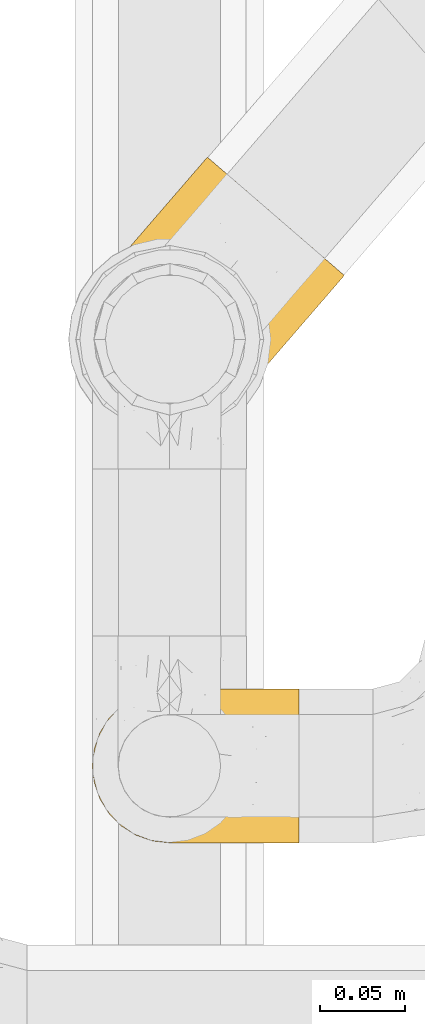
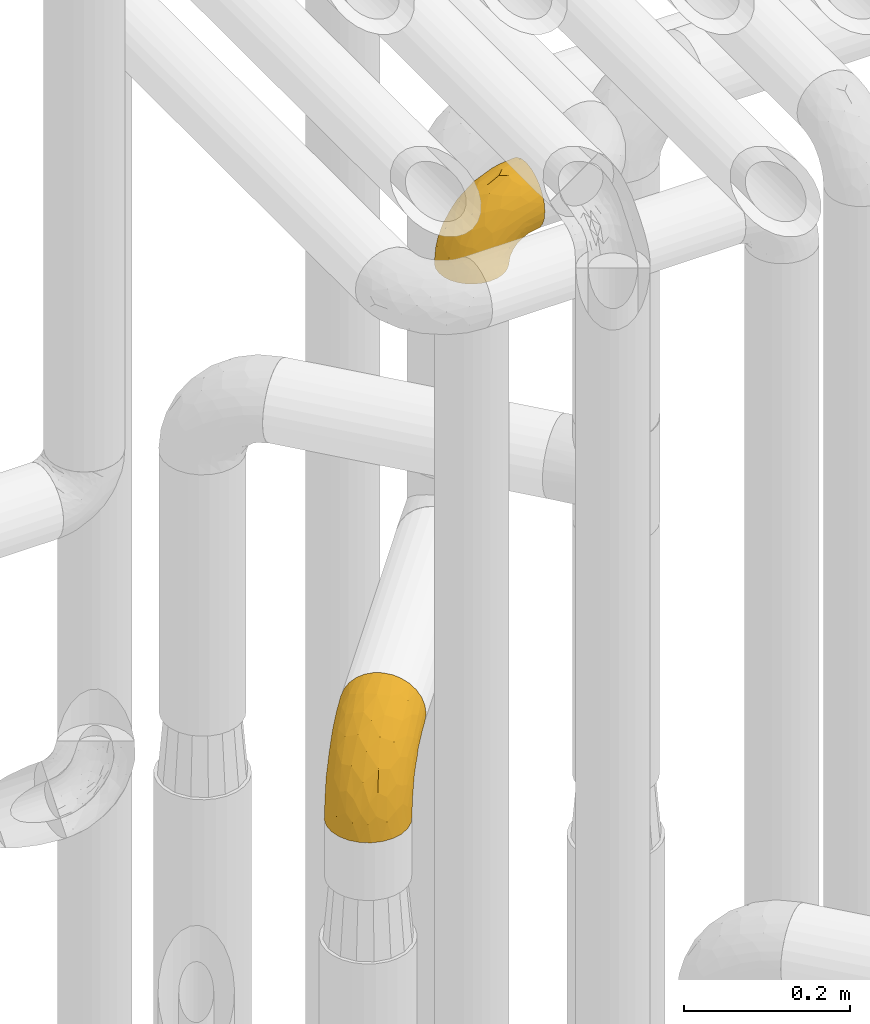
# One storey, part 228 of 827: 2 coverings.
"""IFC2X3 building model written with IfcOpenShell, lengths in millimetres."""

import ifcopenshell
import ifcopenshell.guid

model = None  # the IFC model being written
_history = None  # IfcOwnerHistory: only IFC2X3 demands one
_inside = {}  # id of a spatial element -> (the spatial element, [elements in it])
_under = {}  # id of a project, library or spatial element -> (it, [spatial elements below it])
_declared = {}  # id of a project -> (the project, [libraries it declares])
_typed = {}  # id of a type object -> (the type object, [elements of that type])
_made_of = {}  # id of a material, layer set ... -> (it, [elements and type objects made of it])


def new_model(schema):
    """Start an empty IFC model of exactly this schema.

    Asked for "IFC4X3", IfcOpenShell would pick the latest addendum, in which some entities
    have other attributes; the version numbers below select the first issue.
    IFC2X3 requires an IfcOwnerHistory on every rooted entity: one is made here for all.
    """
    global model, _history
    if schema == "IFC4X3":
        model = ifcopenshell.file(schema_version=(4, 3, 0, 0))
    else:
        model = ifcopenshell.file(schema=schema)
    _inside.clear()
    _under.clear()
    _declared.clear()
    _typed.clear()
    _made_of.clear()
    _history = None
    if model.schema == "IFC2X3":
        org = make("IfcOrganization", Name="unknown")
        user = make(
            "IfcPersonAndOrganization",
            ThePerson=make("IfcPerson", FamilyName="unknown"),
            TheOrganization=org,
        )
        app = make(
            "IfcApplication",
            ApplicationDeveloper=org,
            Version="unknown",
            ApplicationFullName="unknown",
            ApplicationIdentifier="unknown",
        )
        _history = make(
            "IfcOwnerHistory",
            OwningUser=user,
            OwningApplication=app,
            ChangeAction="ADDED",
            CreationDate=0,
        )
    return model


def make(cls, **values):
    """One entity of the class cls with the attributes given. An attribute that is None is left unset."""
    return model.create_entity(
        cls, **{name: value for name, value in values.items() if value is not None}
    )


def entity(cls, *values):
    """Any entity or typed value of the class cls, its attributes in the order of the schema. None: left unset."""
    e = model.create_entity(cls)
    for i, value in enumerate(values):
        if value is not None:
            e[i] = value
    return e


def rooted(cls, **values):
    """An entity with a GlobalId (a new one), such as an element, a storey or a relation."""
    return make(cls, GlobalId=ifcopenshell.guid.new(), OwnerHistory=_history, **values)


def si_unit(unit_type, name, prefix=None):
    """IfcSIUnit, for example si_unit("LENGTHUNIT", "METRE", prefix="MILLI")."""
    return make("IfcSIUnit", UnitType=unit_type, Prefix=prefix, Name=name)


def converted_unit(unit_type, name, factor, base, dimensions=None, offset=None):
    """IfcConversionBasedUnit, such as the inch: factor (a typed value) times the base unit."""
    return make(
        "IfcConversionBasedUnit"
        if offset is None
        else "IfcConversionBasedUnitWithOffset",
        ConversionOffset=offset,
        Dimensions=None
        if dimensions is None
        else entity("IfcDimensionalExponents", *dimensions),
        UnitType=unit_type,
        Name=name,
        ConversionFactor=make(
            "IfcMeasureWithUnit", ValueComponent=factor, UnitComponent=base
        ),
    )


def derived_unit(unit_type, elements):
    """IfcDerivedUnit: a product of units, each with its exponent."""
    return make(
        "IfcDerivedUnit",
        Elements=[
            make("IfcDerivedUnitElement", Unit=unit, Exponent=power)
            for unit, power in elements
        ],
        UnitType=unit_type,
    )


def assignment(units):
    """IfcUnitAssignment: the units of a project."""
    return None if units is None else make("IfcUnitAssignment", Units=units)


def point(xyz):
    """IfcCartesianPoint."""
    return None if xyz is None else make("IfcCartesianPoint", Coordinates=xyz)


def direction(xyz):
    """IfcDirection."""
    return None if xyz is None else make("IfcDirection", DirectionRatios=xyz)


def frame(location, z_axis=None, x_axis=None):
    """IfcAxis2Placement3D, a coordinate frame: its origin and axes. An axis left out is left unset."""
    return make(
        "IfcAxis2Placement3D",
        Location=point(location),
        Axis=direction(z_axis),
        RefDirection=direction(x_axis),
    )


def origin():
    """The frame at (0, 0, 0) with its axes left unset."""
    return frame((0.0, 0.0, 0.0))


def place(relative_to, where):
    """IfcLocalPlacement: puts the frame where relative to a parent placement (None: the world)."""
    return make(
        "IfcLocalPlacement", PlacementRelTo=relative_to, RelativePlacement=where
    )


def context(
    kind, dimensions, precision=None, world=None, true_north=None, identifier=None
):
    """IfcGeometricRepresentationContext, for example the 3D "Model" context."""
    return make(
        "IfcGeometricRepresentationContext",
        ContextIdentifier=identifier,
        ContextType=kind,
        CoordinateSpaceDimension=dimensions,
        Precision=precision,
        WorldCoordinateSystem=world,
        TrueNorth=true_north,
    )


def subcontext(parent, identifier, kind, view, scale=None):
    """IfcGeometricRepresentationSubContext, for example "Body" below "Model"."""
    return make(
        "IfcGeometricRepresentationSubContext",
        ContextIdentifier=identifier,
        ContextType=kind,
        ParentContext=parent,
        TargetScale=scale,
        TargetView=view,
    )


def project(units=None, contexts=None):
    """IfcProject with its units and contexts."""
    return rooted(
        "IfcProject",
        Name="project",
        RepresentationContexts=contexts,
        UnitsInContext=assignment(units),
    )


def spatial(cls, under=None, at=None, **own):
    """A site, building, storey or space (cls), placed at a placement, below another one or the project."""
    s = rooted(cls, ObjectPlacement=at, **own)
    if under is not None:
        _under.setdefault(under.id(), (under, []))[1].append(s)
    return s


def faces_of(points, faces, orient=None, outer=None):
    """IfcFace entities. A face is a list of loops; a loop is a list of indices into points, from 0.

    orient and outer hold one flag for each loop. By default every Orientation is true, the
    first loop of a face is its IfcFaceOuterBound and the others are IfcFaceBound.
    """
    made = []
    for i, loops in enumerate(faces):
        bounds = []
        for j, loop in enumerate(loops):
            is_outer = j == 0 if outer is None else outer[i][j]
            bounds.append(
                make(
                    "IfcFaceOuterBound" if is_outer else "IfcFaceBound",
                    Bound=make("IfcPolyLoop", Polygon=[points[k] for k in loop]),
                    Orientation=True if orient is None else orient[i][j],
                )
            )
        made.append(make("IfcFace", Bounds=bounds))
    return made


def faceted_brep(points, faces, orient=None, outer=None, voids=None):
    """IfcFacetedBrep: a solid bounded by flat faces; with voids (closed shells), ...WithVoids."""
    shared = [point(p) for p in points]
    hull = make("IfcClosedShell", CfsFaces=faces_of(shared, faces, orient, outer))
    if voids is None:
        return make("IfcFacetedBrep", Outer=hull)
    return make(
        "IfcFacetedBrepWithVoids",
        Outer=hull,
        Voids=[
            make(cls, CfsFaces=faces_of(shared, fs, o, b)) for cls, fs, o, b in voids
        ],
    )


def shape(context_of_items, identifier, shape_type, items):
    """IfcShapeRepresentation: the items that make up one representation, for example the "Body"."""
    return make(
        "IfcShapeRepresentation",
        ContextOfItems=context_of_items,
        RepresentationIdentifier=identifier,
        RepresentationType=shape_type,
        Items=items,
    )


def made_of(thing, what):
    """Note that an element or type object is made of a material, layer set ...; save() writes the relation."""
    if what is not None:
        _made_of.setdefault(what.id(), (what, []))[1].append(thing)
    return thing


def element(
    cls,
    number,
    at=None,
    inside=None,
    cuts=None,
    type_object=None,
    material=None,
    context=None,
    identifier="Body",
    shape_type=None,
    held_by="IfcProductDefinitionShape",
    body=None,
    shapes=None,
    **own,
):
    """One element of the class cls, such as IfcWall. Its Tag is "e" and its number.

    at: its placement. inside: the storey or other place that contains it. cuts: it is an
    opening in that element (IfcRelVoidsElement). A single representation is given by context,
    identifier, shape_type and body (its items); several are given by shapes. held_by: the class
    of the entity that holds the representations. save() writes the other relations.
    """
    e = rooted(cls, Tag="e%d" % number, ObjectPlacement=at, **own)
    if body is not None:
        shapes = [shape(context, identifier, shape_type, body)]
    if shapes is not None:
        e.Representation = make(held_by, Representations=shapes)
    if inside is not None:
        _inside.setdefault(inside.id(), (inside, []))[1].append(e)
    if cuts is not None:
        rooted(
            "IfcRelVoidsElement", RelatingBuildingElement=cuts, RelatedOpeningElement=e
        )
    if type_object is not None:
        _typed.setdefault(type_object.id(), (type_object, []))[1].append(e)
    return made_of(e, material)


def aggregate(whole, parts):
    """IfcRelAggregates: a whole, such as a stair, and the parts it consists of."""
    return rooted("IfcRelAggregates", RelatingObject=whole, RelatedObjects=parts)


def save(model, path):
    """Write the relations noted so far, then the file.

    IfcRelAggregates (storeys below a building ...), IfcRelContainedInSpatialStructure (elements
    in a storey), IfcRelDefinesByType, IfcRelAssociatesMaterial and IfcRelDeclares: one each for
    every whole, place, type object, material and project.
    """
    for whole, parts in _under.values():
        aggregate(whole, parts)
    for where, things in _inside.values():
        rooted(
            "IfcRelContainedInSpatialStructure",
            RelatedElements=things,
            RelatingStructure=where,
        )
    for kind, things in _typed.values():
        rooted("IfcRelDefinesByType", RelatedObjects=things, RelatingType=kind)
    for what, things in _made_of.values():
        rooted("IfcRelAssociatesMaterial", RelatedObjects=things, RelatingMaterial=what)
    for by, libraries in _declared.values():
        rooted("IfcRelDeclares", RelatingContext=by, RelatedDefinitions=libraries)
    model.write(path)


model = new_model("IFC2X3")

# Units and contexts
model_context = context("Model", 3, precision=0.01, world=origin(), true_north=direction((6.12303176911189e-17, 1.0)))
body_context = subcontext(model_context, "Body", "Model", "MODEL_VIEW")
ifc_project = project(units=[si_unit("LENGTHUNIT", "METRE", prefix="MILLI"), si_unit("AREAUNIT", "SQUARE_METRE"), si_unit("VOLUMEUNIT", "CUBIC_METRE"), converted_unit("PLANEANGLEUNIT", "DEGREE", entity("IfcRatioMeasure", 0.0174532925199433), si_unit("PLANEANGLEUNIT", "RADIAN"), dimensions=[0, 0, 0, 0, 0, 0, 0]), si_unit("MASSUNIT", "GRAM", prefix="KILO"), derived_unit("MASSDENSITYUNIT", [(si_unit("MASSUNIT", "GRAM", prefix="KILO"), 1), (si_unit("LENGTHUNIT", "METRE"), -3)]), derived_unit("MOMENTOFINERTIAUNIT", [(si_unit("LENGTHUNIT", "METRE"), 4)]), si_unit("TIMEUNIT", "SECOND"), si_unit("FREQUENCYUNIT", "HERTZ"), si_unit("THERMODYNAMICTEMPERATUREUNIT", "DEGREE_CELSIUS"), derived_unit("THERMALTRANSMITTANCEUNIT", [(si_unit("MASSUNIT", "GRAM", prefix="KILO"), 1), (si_unit("THERMODYNAMICTEMPERATUREUNIT", "KELVIN"), -1), (si_unit("TIMEUNIT", "SECOND"), -3)]), derived_unit("VOLUMETRICFLOWRATEUNIT", [(si_unit("LENGTHUNIT", "METRE"), 3), (si_unit("TIMEUNIT", "SECOND"), -1)]), derived_unit("MASSFLOWRATEUNIT", [(si_unit("MASSUNIT", "GRAM", prefix="KILO"), 1), (si_unit("TIMEUNIT", "SECOND"), -1)]), derived_unit("ROTATIONALFREQUENCYUNIT", [(si_unit("TIMEUNIT", "SECOND"), -1)]), si_unit("ELECTRICCURRENTUNIT", "AMPERE"), si_unit("ELECTRICVOLTAGEUNIT", "VOLT"), si_unit("POWERUNIT", "WATT"), si_unit("FORCEUNIT", "NEWTON", prefix="KILO"), si_unit("ILLUMINANCEUNIT", "LUX"), si_unit("LUMINOUSFLUXUNIT", "LUMEN"), si_unit("LUMINOUSINTENSITYUNIT", "CANDELA"), derived_unit("USERDEFINED", [(si_unit("MASSUNIT", "GRAM", prefix="KILO"), -1), (si_unit("LENGTHUNIT", "METRE"), -2), (si_unit("TIMEUNIT", "SECOND"), 3), (si_unit("LUMINOUSFLUXUNIT", "LUMEN"), 1)]), derived_unit("LINEARVELOCITYUNIT", [(si_unit("LENGTHUNIT", "METRE"), 1), (si_unit("TIMEUNIT", "SECOND"), -1)]), si_unit("PRESSUREUNIT", "PASCAL"), derived_unit("USERDEFINED", [(si_unit("LENGTHUNIT", "METRE"), -2), (si_unit("MASSUNIT", "GRAM", prefix="KILO"), 1), (si_unit("TIMEUNIT", "SECOND"), -2)]), derived_unit("LINEARFORCEUNIT", [(si_unit("MASSUNIT", "GRAM", prefix="KILO"), 1), (si_unit("LENGTHUNIT", "METRE"), 1), (si_unit("TIMEUNIT", "SECOND"), -2), (si_unit("LENGTHUNIT", "METRE"), -1)]), derived_unit("PLANARFORCEUNIT", [(si_unit("MASSUNIT", "GRAM", prefix="KILO"), 1), (si_unit("LENGTHUNIT", "METRE"), 1), (si_unit("TIMEUNIT", "SECOND"), -2), (si_unit("LENGTHUNIT", "METRE"), -2)])], contexts=[model_context])

# Site, building, storey
site_placement = place(None, origin())
site = spatial("IfcSite", under=ifc_project, at=site_placement, CompositionType="ELEMENT")
building_placement = place(site_placement, origin())
building = spatial("IfcBuilding", under=site, at=building_placement, CompositionType="ELEMENT")
storey_placement = place(building_placement, frame((0.0, 0.0, 28200.0)))
storey = spatial("IfcBuildingStorey", under=building, at=storey_placement, Name="08", CompositionType="ELEMENT", Elevation=28200.0)

# Coverings
covering_1_placement = place(storey_placement, frame((36582.9, 12284.43, 2922.4)))
element("IfcCovering", 1, at=covering_1_placement, inside=storey, Name=":ADSK_", ObjectType=":ADSK_", PredefinedType="INSULATION", context=body_context, shape_type="Brep", body=[
    faceted_brep([(36.69, 2.73, 1.6), (27.15, 6.07, 1.6), (18.59, 11.45, 1.6), (11.44, 18.6, 1.6), (6.06, 27.16, 1.6), (2.73, 36.7, 1.6), (1.6, 46.75, 1.6), (2.73, 56.8, 1.6), (6.07, 66.34, 1.6), (11.45, 74.9, 1.6), (18.6, 82.05, 1.6), (27.16, 87.43, 1.6), (36.7, 90.76, 1.6), (46.75, 91.9, 1.6), (56.8, 90.76, 1.6), (66.34, 87.42, 1.6), (74.9, 82.04, 1.6), (82.05, 74.89, 1.6), (87.43, 66.33, 1.6), (90.76, 56.79, 1.6), (91.9, 46.75, 1.6), (90.76, 36.69, 1.6), (87.42, 27.15, 1.6), (82.04, 18.59, 1.6), (74.89, 11.44, 1.6), (66.33, 6.06, 1.6), (56.79, 2.73, 1.6), (46.75, 1.6, 1.6), (122.75, 58.43, 33.98), (122.75, 69.32, 38.49), (122.75, 78.67, 45.67), (122.75, 85.85, 55.02), (122.75, 90.36, 65.91), (122.75, 91.9, 77.6), (122.75, 90.36, 89.28), (122.75, 85.85, 100.17), (122.75, 78.67, 109.52), (122.75, 69.32, 116.7), (122.75, 58.43, 121.21), (122.75, 46.75, 122.75), (122.75, 35.06, 121.21), (122.75, 24.17, 116.7), (122.75, 14.82, 109.52), (122.75, 7.64, 100.17), (122.75, 3.13, 89.28), (122.75, 1.6, 77.6), (122.75, 3.13, 65.91), (122.75, 7.64, 55.02), (122.75, 14.82, 45.67), (122.75, 24.17, 38.49), (122.75, 35.06, 33.98), (122.75, 46.75, 32.45), (24.73, 46.75, 72.81), (29.08, 38.29, 77.17), (38.13, 46.75, 86.21), (85.31, 46.75, 116.82), (93.59, 38.96, 118.49), (100.54, 46.75, 119.23), (63.54, 33.86, 105.14), (38.98, 31.42, 85.37), (50.71, 21.63, 89.33), (93.33, 30.84, 116.14), (75.2, 22.16, 105.06), (100.46, 20.56, 112.15), (41.6, 2.29, 22.95), (80.86, 7.18, 89.91), (94.87, 12.6, 103.39), (67.96, 14.0, 93.6), (52.16, 2.81, 51.41), (52.1, 6.65, 67.71), (36.74, 6.11, 43.53), (17.11, 16.62, 30.91), (23.24, 9.76, 23.58), (29.18, 12.46, 50.07), (52.53, 1.6, 30.68), (60.77, 1.6, 43.01), (69.01, 1.6, 55.34), (100.68, 2.46, 83.48), (103.79, 5.91, 94.96), (16.37, 36.97, 57.29), (7.52, 46.75, 39.03), (7.31, 33.09, 30.66), (93.66, 1.6, 71.81), (102.83, 1.6, 73.63), (112.01, 1.6, 75.46), (18.17, 25.62, 51.57), (71.97, 3.14, 73.13), (9.83, 23.92, 23.16), (5.11, 46.75, 23.8), (45.97, 13.58, 75.6), (48.88, 1.6, 12.33), (50.71, 1.6, 21.51), (22.83, 18.5, 50.46), (51.54, 46.75, 99.61), (81.33, 1.6, 63.57), (31.74, 4.96, 21.26), (32.48, 20.84, 69.54), (68.42, 46.75, 108.21), (25.33, 30.52, 68.42), (16.13, 46.75, 55.92), (92.29, 27.29, 19.36), (94.12, 36.89, 15.76), (100.97, 33.6, 26.13), (95.91, 2.54, 62.78), (107.9, 3.27, 63.65), (87.24, 16.85, 24.34), (95.46, 21.91, 28.46), (90.41, 13.5, 33.53), (74.17, 3.96, 39.46), (83.77, 3.52, 51.05), (76.72, 12.17, 10.94), (84.44, 18.93, 14.55), (76.42, 9.34, 22.21), (90.07, 3.12, 57.05), (99.69, 5.67, 54.0), (61.74, 2.51, 29.19), (58.16, 2.53, 18.85), (112.6, 8.35, 52.84), (110.45, 35.39, 31.47), (107.32, 46.75, 28.31), (108.48, 15.1, 43.0), (66.63, 5.27, 16.9), (115.23, 27.43, 35.98), (105.79, 24.89, 33.91), (89.6, 29.71, 9.97), (69.39, 5.07, 25.93), (66.99, 2.88, 35.61), (102.31, 9.69, 47.45), (99.54, 15.51, 38.26), (55.27, 2.27, 11.7), (82.03, 10.03, 30.13), (94.71, 46.75, 12.12), (96.03, 46.75, 17.02), (94.11, 8.83, 44.39), (84.21, 7.16, 39.83), (101.67, 46.75, 22.67), (112.22, 46.75, 29.63), (108.48, 78.39, 43.0), (102.31, 83.8, 47.45), (99.54, 77.97, 38.26), (94.11, 84.66, 44.38), (110.46, 58.1, 31.47), (76.74, 81.31, 10.93), (50.71, 91.9, 21.51), (58.17, 90.96, 18.84), (55.27, 91.22, 11.7), (94.12, 56.59, 15.76), (92.3, 66.18, 19.36), (100.98, 59.87, 26.14), (69.41, 88.42, 25.94), (76.44, 84.13, 22.21), (66.65, 88.22, 16.9), (115.24, 66.06, 35.98), (102.83, 91.9, 73.63), (112.01, 91.9, 75.46), (82.05, 83.44, 30.12), (87.25, 76.62, 24.33), (112.6, 85.14, 52.84), (107.9, 90.22, 63.65), (93.66, 91.9, 71.81), (95.48, 71.55, 28.45), (89.6, 63.77, 9.97), (60.77, 91.9, 43.01), (69.01, 91.9, 55.34), (74.17, 89.53, 39.46), (48.88, 91.9, 12.33), (84.45, 74.55, 14.54), (95.91, 90.95, 62.78), (90.07, 90.37, 57.05), (81.33, 91.9, 63.57), (61.75, 90.98, 29.2), (83.77, 89.97, 51.05), (84.21, 86.32, 39.81), (52.53, 91.9, 30.68), (90.42, 79.97, 33.52), (67.0, 90.61, 35.61), (99.69, 87.82, 54.0), (105.8, 68.6, 33.91), (94.87, 80.89, 103.39), (80.86, 86.31, 89.91), (67.95, 79.49, 93.6), (75.17, 71.33, 105.05), (50.65, 71.88, 89.27), (71.97, 90.35, 73.13), (52.08, 86.85, 67.67), (32.46, 72.67, 69.49), (38.98, 62.08, 85.36), (103.79, 87.58, 94.96), (100.68, 91.03, 83.48), (63.54, 59.62, 105.14), (93.32, 62.65, 116.13), (93.59, 54.53, 118.49), (100.44, 72.93, 112.15), (52.17, 90.68, 51.41), (36.75, 87.39, 43.51), (41.61, 91.2, 22.95), (7.31, 60.41, 30.66), (17.12, 76.88, 30.91), (16.37, 56.53, 57.3), (23.26, 83.74, 23.58), (18.17, 67.88, 51.56), (25.33, 62.99, 68.41), (9.84, 69.58, 23.16), (29.19, 81.04, 50.07), (22.84, 75.0, 50.45), (31.75, 88.53, 21.25), (45.96, 79.93, 75.56), (29.07, 55.21, 77.16)], [[[0, 1, 2, 3, 4, 5, 6, 7, 8, 9, 10, 11, 12, 13, 14, 15, 16, 17, 18, 19, 20, 21, 22, 23, 24, 25, 26, 27]], [[28, 29, 30, 31, 32, 33, 34, 35, 36, 37, 38, 39, 40, 41, 42, 43, 44, 45, 46, 47, 48, 49, 50, 51]], [[52, 53, 54]], [[55, 56, 57]], [[58, 59, 60]], [[61, 62, 63]], [[27, 64, 0]], [[65, 66, 67]], [[41, 40, 61]], [[68, 69, 70]], [[66, 43, 42]], [[63, 42, 41]], [[71, 72, 73]], [[72, 2, 1]], [[68, 74, 75, 76]], [[45, 44, 77]], [[43, 78, 44]], [[79, 80, 81]], [[77, 82, 83, 84, 45]], [[79, 81, 85]], [[71, 2, 72]], [[65, 86, 77]], [[4, 81, 5]], [[66, 65, 78]], [[4, 3, 87]], [[81, 88, 5]], [[63, 66, 42]], [[68, 70, 64]], [[67, 60, 89]], [[71, 3, 2]], [[64, 27, 90, 91, 74]], [[92, 71, 73]], [[40, 57, 56]], [[59, 93, 54]], [[86, 76, 94, 82]], [[1, 0, 95]], [[58, 62, 61]], [[60, 96, 89]], [[85, 81, 87]], [[56, 97, 58]], [[65, 67, 69]], [[87, 81, 4]], [[67, 89, 69]], [[61, 63, 41]], [[95, 72, 1]], [[73, 72, 70]], [[69, 73, 70]], [[73, 89, 96]], [[3, 71, 87]], [[85, 87, 71]], [[58, 61, 56]], [[59, 58, 93]], [[76, 86, 68]], [[69, 89, 73]], [[68, 86, 69]], [[65, 69, 86]], [[68, 64, 74]], [[95, 64, 70]], [[98, 79, 85]], [[79, 52, 99, 80]], [[66, 62, 67]], [[62, 58, 60]], [[62, 60, 67]], [[59, 98, 96]], [[59, 96, 60]], [[96, 85, 92]], [[88, 81, 80]], [[88, 6, 5]], [[66, 63, 62]], [[64, 95, 0]], [[72, 95, 70]], [[77, 44, 78]], [[86, 82, 77]], [[40, 39, 57]], [[96, 98, 85]], [[40, 56, 61]], [[66, 78, 43]], [[77, 78, 65]], [[79, 98, 53]], [[96, 92, 73]], [[85, 71, 92]], [[97, 56, 55]], [[97, 93, 58]], [[53, 98, 59]], [[54, 53, 59]], [[79, 53, 52]], [[100, 101, 102]], [[46, 45, 84, 83]], [[103, 104, 82]], [[82, 104, 83]], [[105, 106, 107]], [[108, 109, 76]], [[110, 111, 112]], [[103, 113, 114]], [[115, 74, 116]], [[48, 47, 117]], [[118, 102, 119]], [[49, 48, 120]], [[74, 91, 116]], [[116, 121, 115]], [[49, 122, 50]], [[123, 106, 102]], [[124, 111, 22]], [[125, 126, 115]], [[23, 22, 111]], [[24, 110, 121]], [[120, 127, 128]], [[90, 26, 129]], [[27, 26, 90]], [[121, 125, 115]], [[24, 121, 25]], [[130, 105, 107]], [[129, 25, 116]], [[21, 20, 131]], [[120, 123, 122]], [[112, 105, 130]], [[50, 118, 51]], [[21, 124, 22]], [[101, 131, 132]], [[117, 120, 48]], [[24, 23, 110]], [[127, 114, 133]], [[75, 108, 76]], [[107, 134, 130]], [[133, 114, 113]], [[129, 116, 91]], [[25, 121, 116]], [[121, 112, 125]], [[75, 74, 115]], [[101, 135, 102]], [[131, 101, 21]], [[101, 100, 124]], [[128, 127, 133]], [[119, 136, 51, 118]], [[104, 47, 46]], [[83, 104, 46]], [[117, 104, 114]], [[101, 124, 21]], [[111, 124, 100]], [[102, 118, 123]], [[133, 134, 107]], [[111, 110, 23]], [[114, 104, 103]], [[94, 76, 109]], [[121, 110, 112]], [[122, 118, 50]], [[134, 109, 108]], [[133, 107, 128]], [[112, 108, 125]], [[126, 125, 108]], [[108, 75, 126]], [[75, 115, 126]], [[109, 134, 133]], [[130, 108, 112]], [[108, 130, 134]], [[105, 112, 111]], [[111, 100, 105]], [[106, 105, 100]], [[102, 106, 100]], [[128, 106, 123]], [[90, 129, 91]], [[25, 129, 26]], [[104, 117, 47]], [[117, 114, 127]], [[82, 94, 103]], [[113, 94, 109]], [[94, 113, 103]], [[133, 113, 109]], [[106, 128, 107]], [[123, 120, 128]], [[120, 122, 49]], [[118, 122, 123]], [[135, 101, 132]], [[135, 119, 102]], [[117, 127, 120]], [[30, 29, 137]], [[138, 139, 140]], [[51, 136, 119, 141]], [[142, 17, 16]], [[143, 144, 145]], [[146, 147, 148]], [[149, 150, 151]], [[152, 29, 28]], [[33, 32, 153, 154]], [[150, 155, 156]], [[157, 31, 30]], [[153, 158, 159]], [[29, 152, 137]], [[148, 141, 119]], [[156, 160, 147]], [[148, 135, 146]], [[137, 138, 157]], [[19, 161, 146]], [[162, 163, 164]], [[14, 13, 165]], [[153, 32, 158]], [[147, 161, 166]], [[18, 17, 166]], [[167, 168, 169]], [[166, 150, 156]], [[151, 150, 142]], [[151, 170, 149]], [[151, 16, 15]], [[171, 140, 172]], [[165, 143, 145]], [[173, 170, 144]], [[142, 166, 17]], [[19, 131, 20]], [[144, 170, 151]], [[18, 161, 19]], [[173, 144, 143]], [[140, 139, 174]], [[171, 164, 163]], [[164, 172, 155]], [[151, 15, 144]], [[145, 15, 14]], [[173, 162, 170]], [[149, 175, 164]], [[19, 146, 131]], [[132, 131, 146]], [[160, 148, 147]], [[159, 158, 167]], [[135, 132, 146]], [[158, 32, 31]], [[157, 158, 31]], [[167, 158, 176]], [[166, 161, 18]], [[146, 161, 147]], [[148, 177, 141]], [[171, 168, 140]], [[171, 163, 169]], [[151, 142, 16]], [[166, 142, 150]], [[152, 141, 177]], [[51, 141, 28]], [[138, 140, 176]], [[172, 140, 174]], [[175, 149, 170]], [[164, 150, 149]], [[170, 162, 175]], [[162, 164, 175]], [[155, 172, 174]], [[171, 172, 164]], [[155, 174, 156]], [[164, 155, 150]], [[160, 156, 174]], [[147, 166, 156]], [[139, 160, 174]], [[148, 160, 177]], [[15, 145, 144]], [[165, 145, 14]], [[137, 157, 30]], [[158, 157, 176]], [[168, 167, 176]], [[169, 159, 167]], [[140, 168, 176]], [[169, 168, 171]], [[137, 177, 139]], [[160, 139, 177]], [[141, 152, 28]], [[137, 152, 177]], [[148, 119, 135]], [[157, 138, 176]], [[139, 138, 137]], [[178, 179, 180]], [[181, 180, 182]], [[179, 183, 184]], [[185, 186, 182]], [[187, 188, 179]], [[188, 33, 154, 153, 159]], [[181, 189, 190]], [[35, 34, 187]], [[191, 38, 190]], [[192, 178, 181]], [[179, 184, 180]], [[192, 190, 37]], [[37, 190, 38]], [[36, 35, 178]], [[54, 93, 186]], [[35, 187, 178]], [[193, 194, 184]], [[195, 173, 143, 165, 13]], [[195, 193, 173]], [[193, 163, 162, 173]], [[13, 12, 195]], [[8, 7, 196]], [[9, 197, 10]], [[198, 80, 99, 52]], [[196, 7, 88]], [[197, 199, 10]], [[182, 189, 181]], [[200, 198, 201]], [[200, 196, 198]], [[9, 8, 202]], [[194, 199, 203]], [[192, 37, 36]], [[80, 196, 88]], [[183, 159, 169, 163]], [[188, 34, 33]], [[202, 200, 197]], [[185, 203, 204]], [[202, 8, 196]], [[10, 199, 11]], [[12, 11, 205]], [[38, 191, 57]], [[189, 97, 191]], [[203, 199, 197]], [[205, 199, 194]], [[204, 203, 197]], [[184, 203, 206]], [[200, 202, 196]], [[197, 9, 202]], [[207, 54, 186]], [[97, 55, 191]], [[194, 203, 184]], [[183, 163, 193]], [[184, 206, 180]], [[183, 193, 184]], [[205, 195, 12]], [[193, 195, 194]], [[80, 198, 196]], [[207, 186, 201]], [[182, 180, 206]], [[181, 178, 180]], [[185, 182, 206]], [[182, 186, 189]], [[203, 185, 206]], [[185, 200, 201]], [[7, 6, 88]], [[178, 192, 36]], [[190, 192, 181]], [[199, 205, 11]], [[195, 205, 194]], [[159, 183, 188]], [[179, 188, 183]], [[57, 191, 55]], [[57, 39, 38]], [[189, 191, 190]], [[188, 187, 34]], [[178, 187, 179]], [[186, 93, 189]], [[197, 200, 204]], [[185, 204, 200]], [[189, 93, 97]], [[207, 198, 52]], [[185, 201, 186]], [[198, 207, 201]], [[54, 207, 52]]]),
])
covering_2_placement = place(storey_placement, frame((36575.42, 12526.85, 1953.4)))
element("IfcCovering", 2, at=covering_2_placement, inside=storey, Name=":ADSK_", ObjectType=":ADSK_", PredefinedType="INSULATION", context=body_context, shape_type="Brep", body=[
    faceted_brep([(107.67, 134.11, 148.32), (116.6, 126.4, 149.65), (125.54, 118.68, 148.31), (134.02, 111.35, 144.39), (141.64, 104.78, 138.06), (147.99, 99.29, 129.66), (152.77, 95.16, 119.6), (155.74, 92.6, 108.39), (156.75, 91.73, 96.6), (155.74, 92.6, 84.79), (152.77, 95.16, 73.57), (147.98, 99.3, 63.51), (141.62, 104.79, 55.11), (134.01, 111.36, 48.79), (125.52, 118.69, 44.87), (116.6, 126.4, 43.55), (107.66, 134.12, 44.88), (99.17, 141.45, 48.8), (91.56, 148.03, 55.13), (85.2, 153.52, 63.53), (80.42, 157.65, 73.59), (77.45, 160.21, 84.8), (76.45, 161.08, 96.6), (77.46, 160.21, 108.41), (80.43, 157.64, 119.62), (85.21, 153.51, 129.68), (91.57, 148.02, 138.08), (99.19, 141.44, 144.4), (98.39, 84.31, 1.6), (104.61, 71.94, 1.6), (107.41, 58.38, 1.6), (106.61, 44.55, 1.6), (102.26, 31.4, 1.6), (94.65, 19.83, 1.6), (84.31, 10.62, 1.6), (71.94, 4.4, 1.6), (58.38, 1.6, 1.6), (44.55, 2.4, 1.6), (31.4, 6.75, 1.6), (19.83, 14.35, 1.6), (10.62, 24.7, 1.6), (4.4, 37.07, 1.6), (1.6, 50.63, 1.6), (2.4, 64.46, 1.6), (6.75, 77.61, 1.6), (14.35, 89.18, 1.6), (24.7, 98.39, 1.6), (37.07, 104.61, 1.6), (50.63, 107.41, 1.6), (64.46, 106.61, 1.6), (77.61, 102.26, 1.6), (89.18, 94.65, 1.6), (4.6, 43.97, 27.97), (10.75, 32.58, 37.09), (11.35, 49.1, 58.27), (14.61, 22.96, 27.13), (23.13, 18.17, 39.91), (40.19, 102.31, 109.11), (26.63, 81.46, 94.41), (38.06, 81.09, 110.94), (28.38, 49.84, 89.69), (32.79, 29.37, 75.62), (48.17, 47.17, 106.28), (14.38, 82.75, 60.12), (6.93, 70.2, 41.41), (12.66, 74.07, 63.22), (8.85, 79.33, 32.05), (17.15, 91.03, 52.13), (52.18, 105.6, 123.27), (57.44, 96.06, 129.32), (74.21, 118.09, 138.3), (16.51, 40.14, 62.95), (19.99, 29.06, 55.89), (4.75, 58.25, 37.4), (91.55, 97.4, 144.6), (80.99, 109.79, 142.66), (48.25, 68.16, 117.85), (66.53, 85.87, 134.01), (26.94, 93.1, 89.25), (60.75, 141.51, 103.34), (61.06, 136.99, 113.52), (26.21, 102.91, 57.43), (21.8, 97.8, 44.19), (17.39, 92.7, 30.95), (27.75, 102.2, 77.98), (71.12, 128.74, 132.66), (58.19, 124.23, 121.52), (22.41, 63.02, 86.93), (13.44, 66.09, 68.4), (39.95, 118.82, 78.45), (33.08, 110.86, 67.94), (67.92, 151.2, 94.53), (57.26, 138.86, 91.95), (44.1, 122.24, 93.36), (48.61, 128.84, 85.2), (41.39, 114.03, 101.45), (68.21, 70.38, 129.81), (15.87, 90.94, 16.27), (84.66, 123.6, 42.46), (72.54, 120.72, 40.4), (69.68, 127.87, 49.71), (29.44, 104.45, 39.4), (37.2, 107.83, 31.26), (26.84, 101.17, 27.7), (23.24, 97.73, 16.7), (52.59, 129.87, 70.67), (58.65, 139.0, 81.69), (36.2, 105.13, 16.68), (92.85, 98.91, 22.57), (91.4, 97.22, 14.26), (80.23, 104.28, 17.68), (53.66, 109.7, 19.58), (53.51, 114.06, 33.49), (64.11, 115.28, 33.01), (96.2, 119.91, 40.69), (108.32, 116.82, 40.15), (102.89, 110.53, 37.93), (84.5, 111.08, 31.04), (46.85, 116.28, 45.29), (69.41, 110.3, 23.55), (69.57, 106.34, 11.36), (40.22, 116.38, 59.1), (53.33, 124.87, 57.42), (43.45, 121.37, 68.96), (43.93, 108.21, 20.38), (67.53, 143.7, 72.46), (68.16, 149.48, 83.66), (66.67, 135.07, 60.66), (78.27, 143.79, 61.01), (81.44, 135.04, 51.85), (94.55, 131.12, 46.07), (97.87, 104.72, 30.25), (35.71, 110.22, 46.65), (60.92, 120.42, 43.0), (109.23, 61.7, 19.58), (140.85, 80.39, 72.44), (100.01, 87.2, 17.67), (120.25, 49.47, 78.45), (122.27, 53.3, 68.97), (129.34, 63.58, 70.65), (113.13, 105.28, 40.69), (118.47, 94.41, 42.45), (106.11, 92.44, 31.04), (118.78, 70.47, 42.99), (116.68, 55.86, 45.18), (113.57, 62.25, 33.46), (132.43, 78.28, 60.64), (124.27, 63.59, 57.37), (106.51, 33.56, 57.43), (102.1, 28.45, 44.19), (107.56, 36.99, 39.35), (96.17, 21.59, 16.27), (101.82, 29.86, 16.7), (137.56, 69.51, 91.95), (128.9, 59.49, 85.2), (137.47, 70.87, 81.68), (112.33, 43.96, 46.68), (109.79, 45.14, 31.26), (107.25, 43.76, 16.68), (104.7, 33.93, 27.7), (139.37, 91.02, 60.99), (130.25, 92.9, 51.84), (117.4, 82.02, 40.41), (124.88, 80.21, 49.72), (124.46, 105.29, 46.06), (148.22, 81.85, 94.53), (103.59, 76.95, 11.35), (113.23, 72.91, 33.02), (146.47, 81.84, 83.65), (109.18, 51.86, 20.38), (113.38, 41.51, 67.94), (107.53, 77.37, 23.53), (117.8, 49.36, 59.12), (97.69, 23.35, 30.95), (55.44, 11.03, 58.27), (51.34, 3.6, 27.97), (65.45, 5.82, 37.4), (76.96, 9.72, 41.41), (29.12, 10.45, 27.21), (39.18, 8.03, 37.09), (33.69, 15.86, 53.2), (96.08, 22.87, 52.13), (139.67, 73.35, 103.34), (135.17, 73.0, 113.5), (115.3, 50.19, 101.45), (85.23, 30.85, 94.41), (103.9, 47.29, 109.08), (83.23, 42.12, 110.95), (123.03, 54.08, 93.36), (105.59, 34.98, 77.98), (85.72, 12.95, 32.05), (45.76, 15.62, 64.63), (105.41, 59.63, 123.25), (125.55, 81.75, 132.65), (95.22, 63.46, 129.32), (119.6, 89.05, 139.96), (68.92, 50.3, 117.85), (53.69, 27.98, 89.69), (122.98, 68.31, 121.51), (79.95, 15.96, 63.23), (96.67, 32.8, 89.17), (105.37, 88.75, 142.66), (71.94, 15.56, 68.4), (67.6, 24.0, 86.94), (88.29, 18.92, 60.12), (85.71, 69.09, 133.2)], [[[0, 1, 2, 3, 4, 5, 6, 7, 8, 9, 10, 11, 12, 13, 14, 15, 16, 17, 18, 19, 20, 21, 22, 23, 24, 25, 26, 27]], [[28, 29, 30, 31, 32, 33, 34, 35, 36, 37, 38, 39, 40, 41, 42, 43, 44, 45, 46, 47, 48, 49, 50, 51]], [[52, 53, 54]], [[55, 39, 56]], [[57, 58, 59]], [[60, 61, 62]], [[63, 64, 65]], [[66, 63, 67]], [[68, 69, 70]], [[53, 71, 54]], [[41, 40, 53]], [[53, 72, 71]], [[73, 42, 52]], [[42, 41, 52]], [[74, 0, 75]], [[69, 76, 77]], [[43, 73, 64]], [[45, 44, 66]], [[57, 78, 58]], [[23, 79, 80]], [[67, 81, 82, 83]], [[67, 84, 81]], [[24, 23, 80]], [[25, 85, 26]], [[86, 85, 25]], [[42, 73, 43]], [[0, 27, 75]], [[25, 24, 86]], [[70, 26, 85]], [[0, 74, 1]], [[68, 85, 86]], [[66, 64, 63]], [[60, 59, 87]], [[54, 87, 88]], [[76, 60, 62]], [[84, 89, 90, 81]], [[79, 22, 91, 92]], [[77, 74, 75]], [[93, 92, 94, 89]], [[80, 86, 24]], [[40, 55, 53]], [[76, 59, 60]], [[93, 84, 95]], [[76, 62, 96]], [[55, 72, 53]], [[70, 27, 26]], [[75, 70, 69]], [[78, 84, 63]], [[93, 79, 92]], [[95, 86, 80]], [[77, 76, 96]], [[59, 69, 68]], [[57, 68, 86]], [[68, 57, 59]], [[59, 58, 87]], [[76, 69, 59]], [[88, 87, 58]], [[87, 54, 71]], [[86, 95, 57]], [[78, 57, 95]], [[84, 78, 95]], [[78, 63, 65]], [[58, 78, 65]], [[54, 88, 73]], [[84, 93, 89]], [[79, 95, 80]], [[79, 93, 95]], [[22, 79, 23]], [[66, 83, 97, 45]], [[84, 67, 63]], [[83, 66, 67]], [[64, 44, 43]], [[64, 66, 44]], [[65, 73, 88]], [[53, 52, 41]], [[73, 52, 54]], [[73, 65, 64]], [[65, 88, 58]], [[39, 55, 40]], [[72, 55, 56]], [[56, 61, 72]], [[60, 72, 61]], [[72, 60, 71]], [[87, 71, 60]], [[27, 70, 75]], [[68, 70, 85]], [[74, 77, 96]], [[69, 77, 75]], [[98, 99, 100]], [[46, 45, 97]], [[101, 102, 103]], [[103, 104, 83]], [[105, 94, 106]], [[107, 103, 102]], [[108, 109, 51, 110]], [[111, 112, 113]], [[114, 115, 116]], [[47, 104, 107]], [[110, 117, 108]], [[49, 48, 111]], [[102, 118, 112]], [[119, 120, 111]], [[50, 49, 120]], [[121, 122, 118]], [[105, 123, 89]], [[124, 48, 107]], [[20, 19, 125]], [[121, 81, 90]], [[117, 119, 99]], [[21, 20, 126]], [[22, 21, 91]], [[105, 125, 127]], [[110, 51, 50]], [[19, 128, 125]], [[16, 15, 115]], [[129, 98, 100]], [[126, 91, 21]], [[128, 129, 127]], [[122, 123, 105]], [[114, 117, 98]], [[17, 16, 130]], [[18, 128, 19]], [[129, 18, 17]], [[125, 106, 126]], [[115, 114, 16]], [[130, 129, 17]], [[114, 98, 130]], [[117, 116, 131, 108]], [[99, 119, 113]], [[122, 121, 123]], [[92, 126, 106]], [[105, 127, 122]], [[132, 121, 118]], [[114, 130, 16]], [[129, 130, 98]], [[50, 120, 110]], [[129, 128, 18]], [[125, 128, 127]], [[125, 126, 20]], [[91, 126, 92]], [[105, 89, 94]], [[105, 106, 125]], [[94, 92, 106]], [[100, 122, 127]], [[118, 122, 133]], [[112, 118, 133]], [[132, 118, 102]], [[132, 102, 101]], [[81, 121, 132]], [[82, 103, 83]], [[132, 101, 81]], [[104, 47, 46]], [[124, 107, 102]], [[48, 47, 107]], [[113, 112, 133]], [[112, 111, 124]], [[99, 113, 133]], [[111, 113, 119]], [[99, 133, 100]], [[117, 99, 98]], [[122, 100, 133]], [[127, 129, 100]], [[103, 82, 101]], [[81, 101, 82]], [[112, 124, 102]], [[48, 124, 111]], [[104, 103, 107]], [[46, 97, 104]], [[111, 120, 49]], [[83, 104, 97]], [[110, 120, 119]], [[117, 110, 119]], [[116, 117, 114]], [[89, 123, 90]], [[90, 123, 121]], [[30, 29, 134]], [[11, 10, 135]], [[51, 109, 108, 136]], [[137, 138, 139]], [[140, 141, 142]], [[143, 144, 145]], [[146, 139, 147]], [[148, 149, 150]], [[151, 32, 152]], [[153, 154, 155]], [[156, 150, 157]], [[158, 157, 159]], [[108, 142, 136]], [[31, 158, 152]], [[160, 161, 12]], [[162, 163, 143]], [[140, 142, 116]], [[142, 141, 162]], [[14, 164, 140]], [[14, 140, 115]], [[9, 8, 165]], [[160, 12, 11]], [[141, 164, 161]], [[13, 12, 161]], [[14, 115, 15]], [[28, 166, 29]], [[135, 139, 146]], [[141, 163, 162]], [[135, 146, 160]], [[143, 167, 162]], [[29, 166, 134]], [[116, 142, 108, 131]], [[165, 153, 168]], [[10, 9, 168]], [[168, 135, 10]], [[138, 147, 139]], [[158, 169, 157]], [[14, 13, 164]], [[116, 115, 140]], [[145, 167, 143]], [[135, 160, 11]], [[168, 153, 155]], [[138, 137, 170]], [[157, 144, 156]], [[147, 144, 143]], [[161, 164, 13]], [[140, 164, 141]], [[142, 171, 136]], [[136, 171, 166]], [[161, 160, 146]], [[165, 168, 9]], [[155, 139, 135]], [[139, 154, 137]], [[168, 155, 135]], [[139, 155, 154]], [[144, 147, 172]], [[163, 147, 143]], [[156, 144, 172]], [[157, 169, 145]], [[172, 148, 156]], [[173, 159, 149]], [[159, 157, 150]], [[152, 159, 173]], [[159, 152, 158]], [[31, 30, 158]], [[169, 30, 134]], [[157, 145, 144]], [[167, 134, 171]], [[134, 167, 145]], [[171, 142, 162]], [[162, 167, 171]], [[163, 141, 161]], [[161, 146, 163]], [[147, 163, 146]], [[148, 150, 156]], [[149, 159, 150]], [[30, 169, 158]], [[145, 169, 134]], [[151, 33, 32]], [[31, 152, 32]], [[152, 173, 151]], [[28, 51, 136]], [[134, 166, 171]], [[28, 136, 166]], [[138, 170, 172]], [[147, 138, 172]], [[148, 172, 170]], [[174, 175, 176]], [[35, 34, 177]], [[178, 179, 180]], [[181, 173, 149, 148]], [[182, 183, 184]], [[185, 186, 187]], [[188, 189, 137]], [[190, 33, 151, 173]], [[191, 179, 174]], [[34, 190, 177]], [[39, 38, 178]], [[192, 193, 194]], [[4, 3, 195]], [[175, 179, 37]], [[38, 37, 179]], [[35, 176, 36]], [[196, 62, 197]], [[181, 190, 173]], [[37, 36, 175]], [[183, 6, 198]], [[189, 148, 170, 137]], [[185, 199, 200]], [[3, 2, 201]], [[202, 185, 203]], [[8, 7, 182]], [[200, 184, 186]], [[183, 7, 6]], [[181, 189, 204]], [[200, 189, 184]], [[5, 198, 6]], [[187, 203, 185]], [[195, 3, 201]], [[205, 196, 194]], [[62, 61, 197]], [[186, 198, 192]], [[180, 179, 191]], [[2, 1, 74]], [[198, 193, 192]], [[193, 5, 4]], [[194, 193, 195]], [[2, 74, 201]], [[5, 193, 198]], [[205, 74, 96]], [[188, 137, 154, 153]], [[62, 196, 96]], [[56, 178, 180]], [[198, 184, 183]], [[184, 188, 182]], [[203, 197, 191]], [[205, 194, 201]], [[187, 192, 194]], [[192, 187, 186]], [[194, 196, 187]], [[197, 187, 196]], [[197, 203, 187]], [[202, 174, 176]], [[200, 186, 185]], [[184, 198, 186]], [[199, 185, 202]], [[189, 200, 204]], [[174, 202, 203]], [[176, 177, 199]], [[189, 181, 148]], [[190, 181, 204]], [[190, 204, 177]], [[190, 34, 33]], [[188, 153, 182]], [[189, 188, 184]], [[182, 153, 165, 8]], [[183, 182, 7]], [[199, 177, 204]], [[35, 177, 176]], [[176, 175, 36]], [[179, 175, 174]], [[200, 199, 204]], [[176, 199, 202]], [[203, 191, 174]], [[180, 197, 61]], [[197, 180, 191]], [[61, 56, 180]], [[39, 178, 56]], [[38, 179, 178]], [[194, 195, 201]], [[4, 195, 193]], [[74, 205, 201]], [[96, 196, 205]]]),
])

save(model, "model.ifc")
